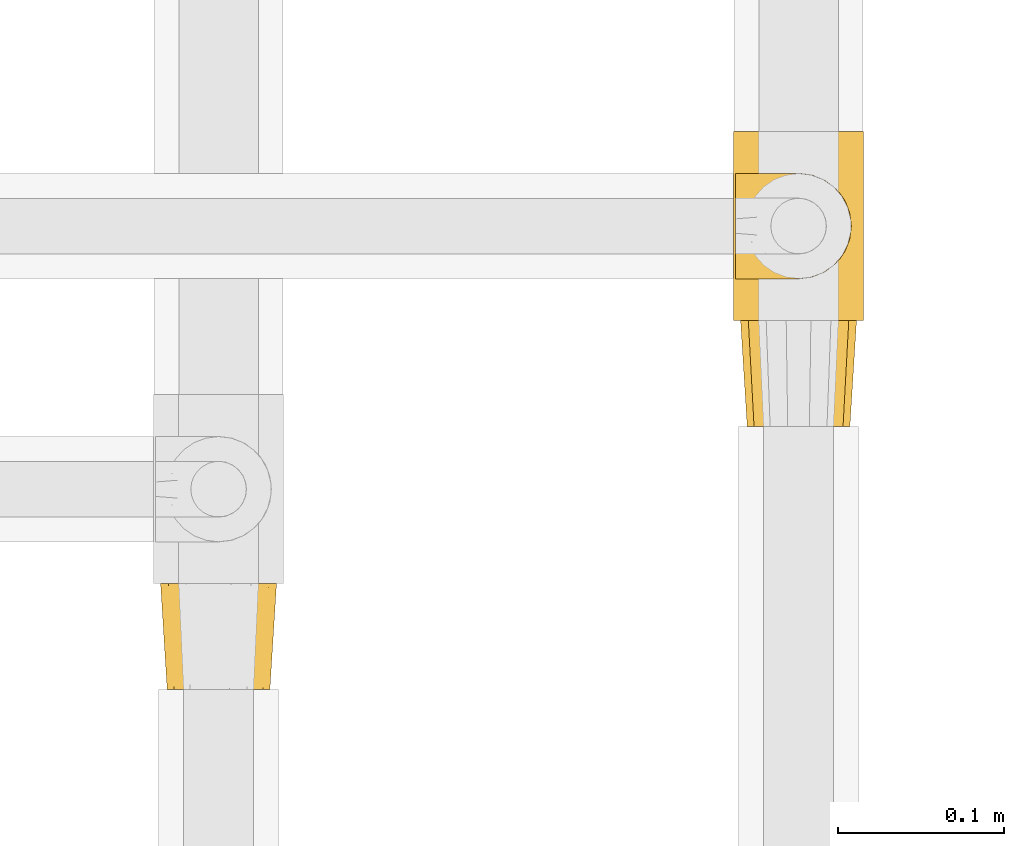
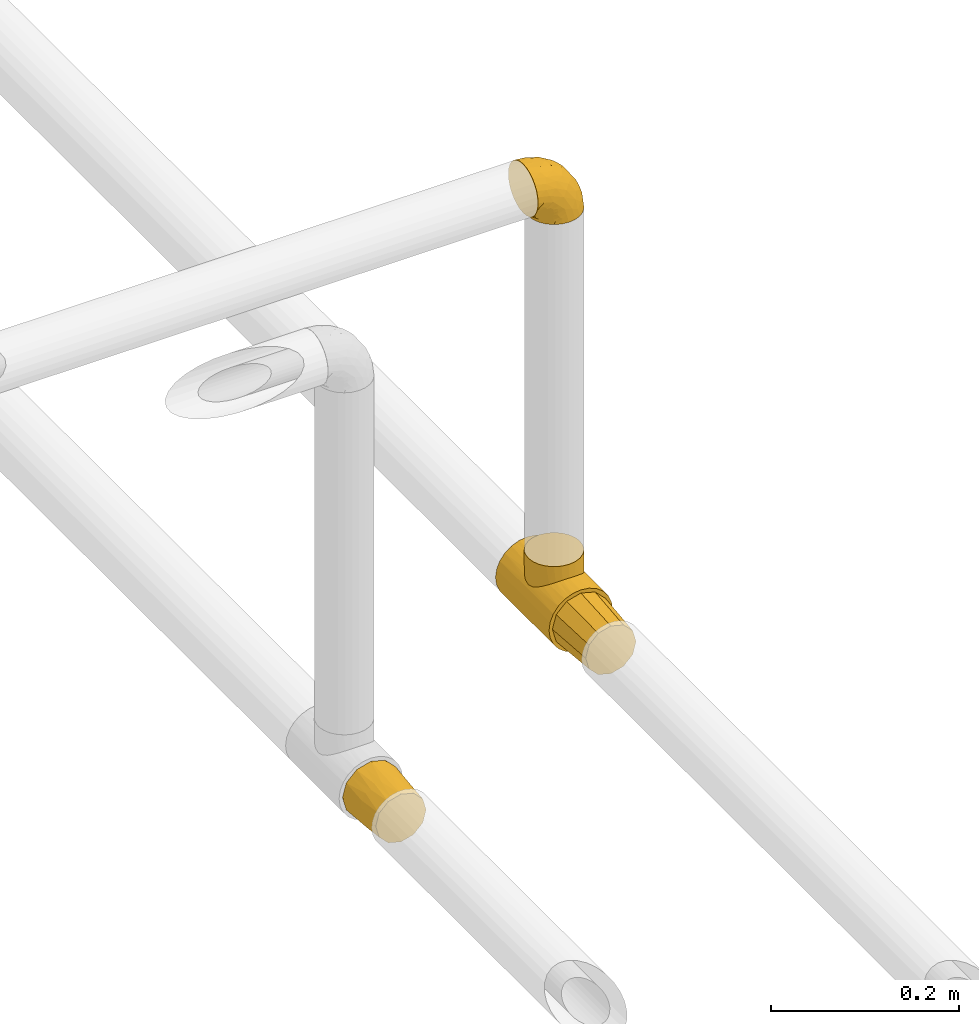
# One storey, part 14 of 38: 4 coverings.
"""IFC2X3 building model written with IfcOpenShell, lengths in millimetres."""

from ifc_helpers import new_model, entity, si_unit, converted_unit, derived_unit, direction, frame, origin, place, context, subcontext, project, spatial, faceted_brep, element, save


model = new_model("IFC2X3")

# Units and contexts
model_context = context("Model", 3, precision=0.01, world=origin(), true_north=direction((6.12303176911189e-17, 1.0)))
body_context = subcontext(model_context, "Body", "Model", "MODEL_VIEW")
ifc_project = project(units=[si_unit("LENGTHUNIT", "METRE", prefix="MILLI"), si_unit("AREAUNIT", "SQUARE_METRE"), si_unit("VOLUMEUNIT", "CUBIC_METRE"), converted_unit("PLANEANGLEUNIT", "DEGREE", entity("IfcRatioMeasure", 0.0174532925199433), si_unit("PLANEANGLEUNIT", "RADIAN"), dimensions=[0, 0, 0, 0, 0, 0, 0]), si_unit("MASSUNIT", "GRAM", prefix="KILO"), derived_unit("MASSDENSITYUNIT", [(si_unit("MASSUNIT", "GRAM", prefix="KILO"), 1), (si_unit("LENGTHUNIT", "METRE"), -3)]), derived_unit("MOMENTOFINERTIAUNIT", [(si_unit("LENGTHUNIT", "METRE"), 4)]), si_unit("TIMEUNIT", "SECOND"), si_unit("FREQUENCYUNIT", "HERTZ"), si_unit("THERMODYNAMICTEMPERATUREUNIT", "DEGREE_CELSIUS"), derived_unit("THERMALTRANSMITTANCEUNIT", [(si_unit("MASSUNIT", "GRAM", prefix="KILO"), 1), (si_unit("THERMODYNAMICTEMPERATUREUNIT", "KELVIN"), -1), (si_unit("TIMEUNIT", "SECOND"), -3)]), derived_unit("VOLUMETRICFLOWRATEUNIT", [(si_unit("LENGTHUNIT", "METRE"), 3), (si_unit("TIMEUNIT", "SECOND"), -1)]), derived_unit("MASSFLOWRATEUNIT", [(si_unit("MASSUNIT", "GRAM", prefix="KILO"), 1), (si_unit("TIMEUNIT", "SECOND"), -1)]), derived_unit("ROTATIONALFREQUENCYUNIT", [(si_unit("TIMEUNIT", "SECOND"), -1)]), si_unit("ELECTRICCURRENTUNIT", "AMPERE"), si_unit("ELECTRICVOLTAGEUNIT", "VOLT"), si_unit("POWERUNIT", "WATT"), si_unit("FORCEUNIT", "NEWTON", prefix="KILO"), si_unit("ILLUMINANCEUNIT", "LUX"), si_unit("LUMINOUSFLUXUNIT", "LUMEN"), si_unit("LUMINOUSINTENSITYUNIT", "CANDELA"), derived_unit("USERDEFINED", [(si_unit("MASSUNIT", "GRAM", prefix="KILO"), -1), (si_unit("LENGTHUNIT", "METRE"), -2), (si_unit("TIMEUNIT", "SECOND"), 3), (si_unit("LUMINOUSFLUXUNIT", "LUMEN"), 1)]), derived_unit("LINEARVELOCITYUNIT", [(si_unit("LENGTHUNIT", "METRE"), 1), (si_unit("TIMEUNIT", "SECOND"), -1)]), si_unit("PRESSUREUNIT", "PASCAL"), derived_unit("USERDEFINED", [(si_unit("LENGTHUNIT", "METRE"), -2), (si_unit("MASSUNIT", "GRAM", prefix="KILO"), 1), (si_unit("TIMEUNIT", "SECOND"), -2)]), derived_unit("LINEARFORCEUNIT", [(si_unit("MASSUNIT", "GRAM", prefix="KILO"), 1), (si_unit("LENGTHUNIT", "METRE"), 1), (si_unit("TIMEUNIT", "SECOND"), -2), (si_unit("LENGTHUNIT", "METRE"), -1)]), derived_unit("PLANARFORCEUNIT", [(si_unit("MASSUNIT", "GRAM", prefix="KILO"), 1), (si_unit("LENGTHUNIT", "METRE"), 1), (si_unit("TIMEUNIT", "SECOND"), -2), (si_unit("LENGTHUNIT", "METRE"), -2)])], contexts=[model_context])

# Site, building, storey
site_placement = place(None, origin())
site = spatial("IfcSite", under=ifc_project, at=site_placement, CompositionType="ELEMENT")
building_placement = place(site_placement, origin())
building = spatial("IfcBuilding", under=site, at=building_placement, CompositionType="ELEMENT")
storey_placement = place(building_placement, frame((0.0, 0.0, 24000.0)))
storey = spatial("IfcBuildingStorey", under=building, at=storey_placement, CompositionType="ELEMENT", Elevation=24000.0)

# Coverings
covering_1_placement = place(storey_placement, frame((31043.4, 8130.17, 2623.4)))
element("IfcCovering", 1, at=covering_1_placement, inside=storey, PredefinedType="INSULATION", context=body_context, shape_type="Brep", body=[
    faceted_brep([(8.36, 0.0, 46.92), (5.59, 0.0, 36.6), (8.36, 0.0, 26.27), (9.75, 0.0, 21.1), (15.42, 0.0, 15.42), (21.09, 0.0, 9.75), (26.27, 0.0, 8.36), (36.59, 0.0, 5.6), (46.92, 0.0, 8.36), (52.09, 0.0, 9.75), (57.77, 0.0, 15.42), (63.44, 0.0, 21.1), (64.83, 0.0, 26.27), (67.59, 0.0, 36.6), (64.83, 0.0, 46.92), (63.44, 0.0, 52.1), (57.77, 0.0, 57.77), (52.09, 0.0, 63.44), (46.92, 0.0, 64.83), (36.59, 0.0, 67.6), (26.27, 0.0, 64.83), (21.09, 0.0, 63.44), (15.42, 0.0, 57.77), (9.75, 0.0, 52.1), (45.35, 64.0, 69.25), (54.1, 64.0, 66.91), (60.5, 64.0, 60.5), (66.91, 64.0, 54.1), (69.25, 64.0, 45.35), (71.6, 64.0, 36.6), (69.25, 64.0, 27.85), (66.91, 64.0, 19.1), (60.5, 64.0, 12.69), (54.1, 64.0, 6.28), (45.35, 64.0, 3.94), (36.6, 64.0, 1.6), (27.85, 64.0, 3.94), (19.1, 64.0, 6.28), (12.69, 64.0, 12.69), (6.28, 64.0, 19.1), (3.94, 64.0, 27.85), (1.6, 64.0, 36.6), (3.94, 64.0, 45.35), (6.28, 64.0, 54.1), (12.69, 64.0, 60.5), (19.1, 64.0, 66.91), (27.85, 64.0, 69.25), (36.6, 64.0, 71.6), (6.68, 32.0, 22.65), (10.56, 28.99, 16.62), (4.58, 28.84, 29.44), (15.12, 32.0, 11.54), (22.65, 32.0, 6.68), (29.44, 28.84, 4.58), (36.59, 32.0, 3.6), (3.59, 32.0, 36.6), (50.54, 32.0, 6.68), (56.57, 28.99, 10.56), (43.75, 28.84, 4.58), (61.65, 32.0, 15.12), (66.51, 32.0, 22.65), (68.61, 28.84, 29.44), (69.59, 32.0, 36.6), (66.51, 32.0, 50.54), (62.63, 28.99, 56.57), (68.61, 28.84, 43.75), (58.07, 32.0, 61.65), (50.54, 32.0, 66.51), (43.75, 28.84, 68.61), (36.59, 32.0, 69.6), (22.65, 32.0, 66.51), (16.62, 28.99, 62.63), (29.44, 28.84, 68.61), (11.54, 32.0, 58.07), (6.68, 32.0, 50.54), (4.58, 28.84, 43.75)], [[[0, 1, 2, 3, 4, 5, 6, 7, 8, 9, 10, 11, 12, 13, 14, 15, 16, 17, 18, 19, 20, 21, 22, 23]], [[24, 25, 26, 27, 28, 29, 30, 31, 32, 33, 34, 35, 36, 37, 38, 39, 40, 41, 42, 43, 44, 45, 46, 47]], [[48, 40, 39]], [[39, 49, 48]], [[41, 40, 50]], [[40, 48, 50]], [[38, 49, 39]], [[51, 49, 38]], [[6, 52, 53]], [[5, 4, 51]], [[48, 2, 50]], [[53, 35, 54, 7]], [[4, 49, 51]], [[49, 3, 48]], [[49, 4, 3]], [[48, 3, 2]], [[2, 1, 50]], [[50, 1, 55, 41]], [[38, 37, 51]], [[51, 37, 52]], [[5, 52, 6]], [[52, 5, 51]], [[37, 36, 52]], [[53, 52, 36]], [[7, 6, 53]], [[35, 53, 36]], [[56, 34, 33]], [[33, 57, 56]], [[35, 34, 58]], [[34, 56, 58]], [[32, 57, 33]], [[59, 57, 32]], [[12, 60, 61]], [[11, 10, 59]], [[56, 8, 58]], [[61, 29, 62, 13]], [[10, 57, 59]], [[57, 9, 56]], [[57, 10, 9]], [[56, 9, 8]], [[8, 7, 58]], [[58, 7, 54, 35]], [[32, 31, 59]], [[59, 31, 60]], [[11, 60, 12]], [[60, 11, 59]], [[31, 30, 60]], [[61, 60, 30]], [[13, 12, 61]], [[29, 61, 30]], [[63, 28, 27]], [[27, 64, 63]], [[29, 28, 65]], [[28, 63, 65]], [[26, 64, 27]], [[66, 64, 26]], [[18, 67, 68]], [[17, 16, 66]], [[63, 14, 65]], [[68, 47, 69, 19]], [[16, 64, 66]], [[64, 15, 63]], [[64, 16, 15]], [[63, 15, 14]], [[14, 13, 65]], [[65, 13, 62, 29]], [[26, 25, 66]], [[66, 25, 67]], [[17, 67, 18]], [[67, 17, 66]], [[25, 24, 67]], [[68, 67, 24]], [[19, 18, 68]], [[47, 68, 24]], [[70, 46, 45]], [[45, 71, 70]], [[47, 46, 72]], [[46, 70, 72]], [[44, 71, 45]], [[73, 71, 44]], [[0, 74, 75]], [[23, 22, 73]], [[70, 20, 72]], [[75, 41, 55, 1]], [[22, 71, 73]], [[71, 21, 70]], [[71, 22, 21]], [[70, 21, 20]], [[20, 19, 72]], [[72, 19, 69, 47]], [[44, 43, 73]], [[73, 43, 74]], [[23, 74, 0]], [[74, 23, 73]], [[43, 42, 74]], [[75, 74, 42]], [[1, 0, 75]], [[41, 75, 42]]]),
])
covering_2_placement = place(storey_placement, frame((31389.25, 8352.96, 2619.25)))
element("IfcCovering", 2, at=covering_2_placement, inside=storey, PredefinedType="INSULATION", context=body_context, shape_type="Brep", body=[
    faceted_brep([(60.32, 114.0, 6.84), (50.88, 114.0, 2.93), (40.75, 114.0, 1.6), (30.61, 114.0, 2.93), (21.17, 114.0, 6.84), (13.06, 114.0, 13.06), (6.84, 114.0, 21.17), (2.93, 114.0, 30.61), (1.6, 114.0, 40.75), (2.93, 114.0, 50.88), (6.84, 114.0, 60.32), (13.06, 114.0, 68.43), (17.12, 114.0, 71.54), (21.17, 114.0, 74.65), (25.89, 114.0, 76.61), (30.61, 114.0, 78.56), (35.68, 114.0, 79.23), (40.75, 114.0, 79.9), (45.81, 114.0, 79.23), (50.88, 114.0, 78.56), (55.6, 114.0, 76.61), (60.32, 114.0, 74.65), (64.37, 114.0, 71.54), (68.43, 114.0, 68.43), (74.65, 114.0, 60.32), (78.56, 114.0, 50.88), (79.9, 114.0, 40.75), (78.56, 114.0, 30.61), (74.65, 114.0, 21.17), (68.43, 114.0, 13.06), (2.93, 0.0, 50.88), (1.6, 0.0, 40.75), (2.93, 0.0, 30.61), (6.84, 0.0, 21.17), (13.06, 0.0, 13.06), (21.17, 0.0, 6.84), (30.61, 0.0, 2.93), (40.75, 0.0, 1.6), (50.88, 0.0, 2.93), (60.32, 0.0, 6.84), (68.43, 0.0, 13.06), (74.65, 0.0, 21.17), (78.56, 0.0, 30.61), (79.9, 0.0, 40.75), (78.56, 0.0, 50.88), (74.65, 0.0, 60.32), (68.43, 0.0, 68.43), (64.37, 0.0, 71.54), (60.32, 0.0, 74.65), (55.6, 0.0, 76.61), (50.88, 0.0, 78.56), (45.81, 0.0, 79.23), (40.75, 0.0, 79.9), (35.68, 0.0, 79.23), (30.61, 0.0, 78.56), (25.89, 0.0, 76.61), (21.17, 0.0, 74.65), (17.12, 0.0, 71.54), (13.06, 0.0, 68.43), (6.84, 0.0, 60.32), (15.77, 37.23, 70.9), (12.16, 42.96, 67.49), (20.53, 32.39, 74.27), (29.82, 86.7, 78.17), (26.39, 85.43, 77.17), (9.77, 49.58, 64.69), (8.9, 57.0, 63.51), (9.77, 64.42, 64.69), (37.0, 88.4, 79.53), (40.75, 88.85, 79.9), (40.75, 25.15, 79.9), (37.0, 25.6, 79.53), (12.16, 71.04, 67.49), (15.77, 76.77, 70.9), (20.53, 81.61, 74.27), (26.39, 28.57, 77.17), (33.25, 26.04, 79.17), (29.82, 27.3, 78.17), (33.25, 87.96, 79.17), (44.49, 25.6, 79.53), (48.24, 26.04, 79.17), (55.1, 28.57, 77.17), (60.96, 32.39, 74.27), (51.67, 27.3, 78.17), (48.24, 87.96, 79.17), (44.49, 88.4, 79.53), (55.1, 85.43, 77.17), (60.96, 81.61, 74.27), (51.67, 86.7, 78.17), (65.72, 76.77, 70.9), (65.72, 37.23, 70.9), (69.33, 42.96, 67.49), (71.72, 49.58, 64.69), (72.6, 57.0, 63.51), (69.33, 71.04, 67.49), (71.72, 64.42, 64.69), (8.9, 57.0, 97.75), (9.98, 48.76, 97.75), (13.16, 41.07, 97.75), (18.22, 34.48, 97.75), (24.82, 29.42, 97.75), (32.5, 26.24, 97.75), (40.75, 25.15, 97.75), (48.99, 26.24, 97.75), (56.67, 29.42, 97.75), (63.27, 34.48, 97.75), (68.33, 41.07, 97.75), (71.51, 48.76, 97.75), (72.6, 57.0, 97.75), (71.51, 65.24, 97.75), (68.33, 72.92, 97.75), (63.27, 79.52, 97.75), (56.67, 84.58, 97.75), (48.99, 87.76, 97.75), (40.75, 88.85, 97.75), (32.5, 87.76, 97.75), (24.82, 84.58, 97.75), (18.22, 79.52, 97.75), (13.16, 72.92, 97.75), (9.98, 65.24, 97.75)], [[[0, 1, 2, 3, 4, 5, 6, 7, 8, 9, 10, 11, 12, 13, 14, 15, 16, 17, 18, 19, 20, 21, 22, 23, 24, 25, 26, 27, 28, 29]], [[30, 31, 32, 33, 34, 35, 36, 37, 38, 39, 40, 41, 42, 43, 44, 45, 46, 47, 48, 49, 50, 51, 52, 53, 54, 55, 56, 57, 58, 59]], [[35, 34, 5, 4]], [[3, 2, 37, 36]], [[36, 35, 4, 3]], [[6, 33, 32, 7]], [[7, 32, 31, 8]], [[5, 34, 33, 6]], [[30, 9, 8, 31]], [[59, 10, 9, 30]], [[58, 60, 61]], [[57, 56, 62]], [[63, 14, 64]], [[61, 65, 58]], [[60, 58, 57]], [[58, 65, 59]], [[65, 66, 59]], [[67, 11, 10]], [[17, 68, 69]], [[70, 71, 52]], [[72, 11, 67]], [[73, 11, 72]], [[74, 12, 73]], [[67, 10, 66]], [[66, 10, 59]], [[75, 56, 55]], [[62, 56, 75]], [[76, 54, 53]], [[55, 54, 77]], [[14, 63, 15]], [[52, 71, 53]], [[76, 53, 71]], [[77, 75, 55]], [[74, 13, 12]], [[54, 76, 77]], [[13, 64, 14]], [[64, 13, 74]], [[16, 78, 68]], [[73, 12, 11]], [[17, 16, 68]], [[16, 15, 78]], [[78, 15, 63]], [[60, 57, 62]], [[51, 79, 52]], [[80, 51, 50]], [[49, 48, 81]], [[82, 81, 48]], [[47, 82, 48]], [[50, 83, 80]], [[51, 80, 79]], [[84, 18, 85]], [[85, 17, 69]], [[52, 79, 70]], [[86, 87, 21]], [[17, 85, 18]], [[19, 88, 20]], [[89, 22, 87]], [[20, 88, 86]], [[82, 47, 90]], [[83, 49, 81]], [[90, 46, 91]], [[46, 90, 47]], [[91, 46, 92]], [[49, 83, 50]], [[24, 45, 44, 25]], [[93, 92, 45]], [[45, 92, 46]], [[44, 43, 26, 25]], [[84, 19, 18]], [[94, 95, 23]], [[86, 21, 20]], [[22, 21, 87]], [[23, 89, 94]], [[95, 24, 23]], [[19, 84, 88]], [[93, 24, 95]], [[93, 45, 24]], [[89, 23, 22]], [[27, 42, 41, 28]], [[28, 41, 40, 29]], [[43, 42, 27, 26]], [[0, 39, 38, 1]], [[1, 38, 37, 2]], [[29, 40, 39, 0]], [[96, 97, 98, 99, 100, 101, 102, 103, 104, 105, 106, 107, 108, 109, 110, 111, 112, 113, 114, 115, 116, 117, 118, 119]], [[76, 102, 101]], [[75, 101, 100]], [[102, 76, 71, 70]], [[62, 75, 100]], [[101, 75, 77, 76]], [[100, 99, 62]], [[60, 99, 98]], [[61, 98, 97]], [[65, 97, 96]], [[60, 98, 61]], [[65, 61, 97]], [[66, 65, 96]], [[99, 60, 62]], [[67, 96, 119]], [[72, 119, 118]], [[66, 96, 67]], [[67, 119, 72]], [[118, 73, 72]], [[118, 117, 73]], [[74, 117, 116]], [[64, 116, 115]], [[78, 115, 114]], [[64, 74, 116]], [[114, 69, 68, 78]], [[115, 78, 63, 64]], [[117, 74, 73]], [[84, 114, 113]], [[86, 113, 112]], [[114, 84, 85, 69]], [[87, 86, 112]], [[113, 86, 88, 84]], [[112, 111, 87]], [[89, 111, 110]], [[94, 110, 109]], [[95, 109, 108]], [[89, 110, 94]], [[95, 94, 109]], [[93, 95, 108]], [[111, 89, 87]], [[92, 108, 107]], [[91, 107, 106]], [[93, 108, 92]], [[92, 107, 91]], [[106, 90, 91]], [[106, 105, 90]], [[82, 105, 104]], [[81, 104, 103]], [[80, 103, 102]], [[81, 82, 104]], [[102, 70, 79, 80]], [[103, 80, 83, 81]], [[105, 82, 90]]]),
])
covering_3_placement = place(storey_placement, frame((31390.4, 8376.51, 3160.4)))
element("IfcCovering", 3, at=covering_3_placement, inside=storey, PredefinedType="INSULATION", context=body_context, shape_type="Brep", body=[
    faceted_brep([(1.6, 26.36, 70.65), (1.6, 33.45, 71.45), (1.6, 40.54, 70.65), (1.6, 47.27, 68.29), (1.6, 53.31, 64.49), (1.6, 58.35, 59.45), (1.6, 62.14, 53.41), (1.6, 64.5, 46.68), (1.6, 65.3, 39.6), (1.6, 64.86, 35.69), (1.6, 64.5, 32.5), (1.6, 63.32, 29.14), (1.6, 62.14, 25.77), (1.6, 58.34, 19.73), (1.6, 53.3, 14.69), (1.6, 47.26, 10.9), (1.6, 40.53, 8.54), (1.6, 33.45, 7.75), (1.6, 26.35, 8.54), (1.6, 19.62, 10.9), (1.6, 13.58, 14.7), (1.6, 8.54, 19.74), (1.6, 4.75, 25.78), (1.6, 3.57, 29.15), (1.6, 2.39, 32.51), (1.6, 2.03, 35.69), (1.6, 1.81, 37.64), (1.6, 1.6, 39.6), (1.6, 2.39, 46.69), (1.6, 4.75, 53.42), (1.6, 8.55, 59.46), (1.6, 13.59, 64.5), (1.6, 19.63, 68.29), (23.67, 61.03, 1.6), (27.51, 62.62, 1.6), (31.35, 64.21, 1.6), (35.67, 64.78, 1.6), (37.63, 65.04, 1.6), (39.6, 65.3, 1.6), (47.84, 64.21, 1.6), (55.52, 61.03, 1.6), (62.12, 55.97, 1.6), (67.18, 49.37, 1.6), (70.36, 41.69, 1.6), (71.45, 33.45, 1.6), (70.36, 25.2, 1.6), (67.18, 17.52, 1.6), (62.12, 10.92, 1.6), (55.52, 5.86, 1.6), (47.84, 2.68, 1.6), (39.6, 1.6, 1.6), (35.67, 2.11, 1.6), (31.35, 2.68, 1.6), (27.51, 4.27, 1.6), (23.67, 5.86, 1.6), (20.37, 8.39, 1.6), (17.07, 10.92, 1.6), (12.01, 17.52, 1.6), (8.83, 25.2, 1.6), (7.75, 33.45, 1.6), (8.83, 41.69, 1.6), (12.01, 49.37, 1.6), (17.07, 55.97, 1.6), (20.37, 58.5, 1.6), (33.94, 2.87, 35.56), (20.6, 1.6, 34.5), (24.07, 1.6, 31.03), (27.55, 1.6, 27.55), (31.03, 1.6, 24.07), (34.5, 1.6, 20.6), (68.79, 33.45, 14.96), (53.62, 10.76, 32.2), (50.17, 5.89, 25.13), (58.62, 9.64, 17.37), (67.51, 22.45, 17.86), (61.03, 16.56, 27.91), (64.5, 15.17, 13.85), (17.98, 12.49, 61.37), (61.71, 25.02, 34.87), (52.25, 18.64, 44.22), (16.72, 2.29, 43.56), (39.09, 6.11, 40.93), (25.86, 5.18, 48.36), (44.07, 2.43, 17.22), (44.36, 11.11, 44.67), (31.35, 26.19, 63.86), (17.72, 24.02, 68.09), (29.45, 19.02, 61.87), (52.37, 4.77, 12.15), (35.28, 1.6, 17.69), (36.06, 1.6, 14.79), (36.84, 1.6, 11.89), (37.61, 1.6, 8.99), (38.11, 1.6, 7.14), (38.61, 1.6, 5.29), (14.07, 7.57, 56.77), (13.65, 17.54, 66.08), (14.96, 33.45, 68.79), (13.32, 4.36, 51.2), (3.44, 1.6, 39.1), (5.29, 1.6, 38.61), (8.99, 1.6, 37.61), (11.89, 1.6, 36.84), (14.79, 1.6, 36.06), (17.69, 1.6, 35.28), (29.19, 9.86, 54.2), (28.91, 14.05, 58.65), (68.17, 28.37, 21.36), (28.33, 33.45, 66.13), (53.45, 25.8, 46.99), (58.56, 33.45, 39.66), (50.99, 33.45, 50.99), (43.14, 22.54, 55.34), (39.23, 15.6, 53.83), (66.13, 33.45, 28.33), (45.6, 28.45, 55.34), (39.66, 33.45, 58.56), (18.04, 9.47, 6.06), (22.76, 5.83, 8.03), (21.95, 5.65, 11.06), (32.18, 2.31, 8.19), (29.08, 2.89, 10.89), (20.77, 2.68, 24.37), (4.75, 22.04, 9.23), (11.03, 5.47, 22.33), (6.78, 5.05, 24.59), (5.68, 7.86, 20.19), (7.71, 25.25, 5.45), (4.42, 28.09, 7.56), (5.94, 33.45, 5.94), (14.52, 12.77, 6.36), (11.63, 2.62, 29.84), (6.6, 3.56, 28.12), (7.33, 11.92, 14.94), (12.48, 11.98, 11.12), (7.99, 17.45, 9.87), (11.14, 17.1, 6.36), (14.07, 7.66, 16.34), (15.37, 4.47, 22.18), (10.81, 7.62, 18.62), (7.89, 2.29, 32.34), (26.18, 3.16, 15.29), (5.8, 16.64, 11.7), (9.94, 12.23, 13.14), (22.23, 4.54, 15.04), (18.39, 7.84, 10.61), (17.71, 2.55, 27.21), (16.87, 7.37, 14.05), (13.24, 3.18, 27.14), (24.95, 4.97, 5.74), (26.59, 2.38, 19.92), (26.16, 1.99, 23.61), (22.11, 3.56, 19.14), (17.43, 4.66, 20.12), (4.75, 44.85, 9.23), (5.8, 50.24, 11.69), (7.99, 49.43, 9.87), (14.07, 59.23, 16.33), (10.06, 54.76, 13.17), (11.54, 59.54, 18.65), (7.71, 41.64, 5.45), (7.89, 64.6, 32.33), (8.99, 65.3, 37.61), (11.89, 65.3, 36.84), (14.79, 65.3, 36.06), (4.42, 38.79, 7.56), (22.42, 62.38, 14.85), (27.95, 64.44, 17.26), (22.22, 61.27, 10.58), (39.1, 65.3, 3.44), (36.84, 65.3, 11.89), (37.61, 65.3, 8.99), (38.61, 65.3, 5.29), (21.49, 59.93, 5.65), (26.52, 62.73, 6.88), (18.09, 60.51, 14.93), (18.39, 59.05, 10.6), (13.88, 56.02, 11.09), (11.14, 49.79, 6.36), (32.18, 64.58, 8.19), (34.5, 65.3, 20.6), (31.03, 65.3, 24.07), (11.65, 64.27, 29.86), (5.67, 59.01, 20.16), (6.81, 61.84, 24.58), (5.29, 65.3, 38.61), (7.14, 65.3, 38.11), (7.34, 54.97, 14.93), (36.06, 65.3, 14.79), (31.38, 64.66, 12.32), (19.83, 63.94, 23.91), (27.55, 65.3, 27.55), (22.94, 63.6, 19.33), (6.6, 63.33, 28.11), (17.93, 57.32, 6.0), (14.52, 54.15, 6.44), (17.45, 64.5, 28.13), (11.03, 61.42, 22.32), (17.69, 65.3, 35.28), (20.6, 65.3, 34.5), (12.33, 63.43, 26.65), (30.27, 64.69, 15.34), (35.28, 65.3, 17.69), (25.9, 62.87, 10.31), (24.07, 65.3, 31.03), (58.62, 57.25, 17.37), (13.32, 62.54, 51.19), (16.72, 64.6, 43.56), (44.07, 64.46, 17.22), (61.71, 41.87, 34.87), (67.51, 44.44, 17.86), (61.03, 50.33, 27.92), (50.18, 61.0, 25.12), (33.92, 64.03, 35.57), (39.08, 60.79, 40.93), (53.62, 56.13, 32.19), (68.17, 38.52, 21.36), (52.37, 62.12, 12.15), (64.5, 51.72, 13.85), (25.86, 61.71, 48.35), (14.07, 59.33, 56.76), (29.18, 57.04, 54.19), (29.46, 47.88, 61.86), (17.73, 42.88, 68.09), (31.37, 40.71, 63.85), (17.99, 54.41, 61.36), (53.45, 41.09, 47.0), (39.25, 51.29, 53.81), (28.92, 52.85, 58.64), (13.65, 49.36, 66.07), (52.23, 48.25, 44.24), (43.13, 44.35, 55.34), (44.36, 55.79, 44.67), (45.6, 38.44, 55.34)], [[[0, 1, 2, 3, 4, 5, 6, 7, 8, 9, 10, 11, 12, 13, 14, 15, 16, 17, 18, 19, 20, 21, 22, 23, 24, 25, 26, 27, 28, 29, 30, 31, 32]], [[33, 34, 35, 36, 37, 38, 39, 40, 41, 42, 43, 44, 45, 46, 47, 48, 49, 50, 51, 52, 53, 54, 55, 56, 57, 58, 59, 60, 61, 62, 63]], [[64, 65, 66, 67, 68, 69]], [[45, 44, 70]], [[71, 72, 73]], [[74, 75, 76]], [[77, 31, 30]], [[75, 78, 79]], [[27, 80, 28]], [[74, 46, 45]], [[64, 81, 82]], [[46, 76, 47]], [[83, 50, 49]], [[48, 47, 73]], [[71, 79, 84]], [[85, 86, 87]], [[49, 48, 88]], [[83, 69, 89, 90, 91, 92, 93, 94, 50]], [[95, 77, 30]], [[75, 74, 78]], [[87, 86, 96]], [[96, 86, 32]], [[96, 32, 31]], [[0, 86, 97]], [[83, 64, 69]], [[98, 80, 82]], [[73, 72, 88]], [[64, 80, 65]], [[1, 0, 97]], [[80, 27, 99, 100, 101, 102, 103, 104, 65]], [[77, 105, 106]], [[64, 82, 80]], [[70, 107, 45]], [[77, 95, 105]], [[82, 95, 98]], [[95, 30, 29]], [[74, 107, 78]], [[86, 0, 32]], [[72, 71, 81]], [[85, 108, 86]], [[76, 73, 47]], [[71, 84, 81]], [[109, 110, 111]], [[87, 112, 85]], [[79, 109, 112]], [[79, 112, 113]], [[88, 83, 49]], [[64, 83, 72]], [[31, 77, 96]], [[87, 96, 77]], [[98, 95, 29]], [[105, 95, 82]], [[81, 105, 82]], [[105, 84, 113]], [[29, 28, 98]], [[114, 107, 70]], [[80, 98, 28]], [[73, 75, 71]], [[79, 71, 75]], [[74, 76, 46]], [[73, 76, 75]], [[78, 107, 114]], [[45, 107, 74]], [[87, 113, 112]], [[115, 85, 112]], [[109, 79, 78]], [[113, 87, 106]], [[116, 115, 111]], [[116, 108, 85]], [[79, 113, 84]], [[109, 78, 110]], [[115, 109, 111]], [[85, 115, 116]], [[109, 115, 112]], [[72, 81, 64]], [[105, 81, 84]], [[73, 88, 48]], [[83, 88, 72]], [[86, 108, 97]], [[78, 114, 110]], [[113, 106, 105]], [[87, 77, 106]], [[117, 118, 119]], [[52, 120, 54, 53]], [[91, 120, 52]], [[91, 90, 120]], [[90, 121, 120]], [[122, 67, 66]], [[18, 123, 19]], [[124, 125, 126]], [[127, 59, 58]], [[128, 129, 127]], [[130, 57, 117]], [[131, 132, 125]], [[19, 133, 20]], [[128, 18, 17]], [[134, 135, 136]], [[137, 138, 139]], [[131, 103, 140]], [[22, 140, 23]], [[131, 65, 104, 103]], [[99, 27, 26, 25, 24, 101, 100]], [[141, 118, 121]], [[19, 123, 142]], [[52, 51, 50, 94, 93, 92, 91]], [[129, 128, 17]], [[117, 56, 118]], [[135, 134, 143]], [[139, 126, 133]], [[119, 144, 145]], [[127, 135, 123]], [[136, 58, 57]], [[101, 24, 23]], [[124, 138, 146]], [[140, 101, 23]], [[145, 147, 134]], [[140, 132, 131]], [[140, 103, 102, 101]], [[140, 22, 132]], [[146, 148, 124]], [[121, 69, 141]], [[55, 149, 118]], [[150, 151, 152]], [[147, 137, 134]], [[144, 150, 152]], [[152, 151, 122]], [[138, 122, 146]], [[59, 127, 129]], [[123, 18, 128]], [[58, 136, 127]], [[135, 127, 136]], [[121, 90, 89, 69]], [[120, 121, 149]], [[122, 66, 146]], [[153, 122, 138]], [[141, 69, 68]], [[127, 123, 128]], [[123, 135, 142]], [[143, 142, 135]], [[19, 142, 133]], [[66, 65, 146]], [[148, 65, 131]], [[22, 21, 132]], [[125, 132, 21]], [[126, 125, 21]], [[148, 125, 124]], [[21, 20, 126]], [[133, 126, 20]], [[139, 138, 124]], [[153, 138, 137]], [[126, 139, 124]], [[139, 133, 143]], [[147, 153, 137]], [[152, 122, 153]], [[134, 136, 130]], [[137, 139, 143]], [[144, 147, 145]], [[153, 147, 152]], [[65, 148, 146]], [[125, 148, 131]], [[141, 144, 119]], [[55, 54, 149]], [[137, 143, 134]], [[142, 143, 133]], [[130, 117, 145]], [[57, 56, 117]], [[134, 130, 145]], [[57, 130, 136]], [[150, 144, 141]], [[147, 144, 152]], [[141, 68, 150]], [[151, 68, 67]], [[117, 119, 145]], [[141, 119, 118]], [[68, 151, 150]], [[122, 151, 67]], [[118, 56, 55]], [[120, 149, 54]], [[118, 149, 121]], [[154, 155, 156]], [[157, 158, 159]], [[129, 160, 59]], [[161, 162, 163, 164]], [[165, 160, 129]], [[166, 167, 168]], [[169, 38, 37, 36, 35, 170, 171, 172]], [[63, 173, 174]], [[175, 176, 177]], [[60, 178, 61]], [[179, 35, 34, 33]], [[160, 60, 59]], [[180, 167, 181]], [[129, 17, 165]], [[182, 161, 164]], [[183, 13, 184]], [[9, 8, 185, 186, 162, 10]], [[187, 155, 15]], [[188, 179, 189]], [[187, 15, 14]], [[190, 191, 192]], [[182, 193, 161]], [[194, 176, 168]], [[176, 195, 177]], [[196, 190, 197]], [[11, 10, 162]], [[11, 161, 12]], [[187, 14, 183]], [[12, 161, 193]], [[156, 158, 177]], [[165, 17, 16]], [[194, 195, 176]], [[187, 159, 158]], [[179, 174, 189]], [[182, 164, 198, 199]], [[200, 199, 196]], [[193, 184, 13]], [[194, 168, 173]], [[201, 202, 189]], [[16, 154, 165]], [[160, 156, 178]], [[160, 165, 154]], [[178, 60, 160]], [[170, 35, 179]], [[188, 170, 179]], [[189, 174, 203]], [[174, 179, 33]], [[201, 189, 203]], [[181, 192, 191]], [[167, 180, 201]], [[192, 175, 190]], [[159, 190, 157]], [[15, 154, 16]], [[204, 196, 199]], [[204, 191, 190]], [[160, 154, 156]], [[15, 155, 154]], [[158, 155, 187]], [[203, 173, 168]], [[192, 181, 167]], [[190, 196, 204]], [[200, 196, 197]], [[184, 193, 182]], [[13, 12, 193]], [[200, 184, 182]], [[184, 200, 183]], [[187, 183, 197]], [[14, 13, 183]], [[162, 161, 11]], [[63, 62, 173]], [[174, 33, 63]], [[173, 62, 194]], [[174, 173, 203]], [[62, 61, 194]], [[195, 61, 178]], [[61, 195, 194]], [[177, 195, 178]], [[156, 177, 178]], [[175, 192, 166]], [[166, 168, 176]], [[167, 203, 168]], [[175, 166, 176]], [[167, 166, 192]], [[177, 157, 175]], [[190, 175, 157]], [[187, 197, 159]], [[190, 159, 197]], [[177, 158, 157]], [[155, 158, 156]], [[167, 201, 203]], [[200, 197, 183]], [[202, 201, 180]], [[202, 188, 189]], [[199, 200, 182]], [[41, 40, 205]], [[206, 207, 7]], [[208, 38, 169, 172, 171, 170, 188, 202, 180]], [[209, 210, 211]], [[212, 213, 214]], [[212, 215, 205]], [[43, 210, 216]], [[217, 40, 39]], [[216, 114, 70]], [[208, 213, 212]], [[205, 40, 217]], [[218, 42, 41]], [[216, 209, 114]], [[42, 218, 210]], [[214, 213, 219]], [[219, 220, 221]], [[199, 207, 213]], [[213, 207, 219]], [[8, 7, 207]], [[222, 223, 224]], [[4, 225, 5]], [[2, 97, 223]], [[110, 226, 111]], [[225, 220, 5]], [[227, 221, 228]], [[223, 229, 3]], [[2, 223, 3]], [[230, 231, 226]], [[224, 223, 108]], [[42, 210, 43]], [[230, 209, 211]], [[222, 225, 229]], [[38, 208, 39]], [[3, 229, 4]], [[213, 180, 181, 191, 204, 199]], [[220, 206, 6]], [[5, 220, 6]], [[207, 199, 198, 164, 163, 162, 186, 185, 8]], [[212, 214, 215]], [[218, 205, 211]], [[211, 215, 230]], [[226, 110, 209]], [[222, 231, 227]], [[222, 224, 231]], [[213, 208, 180]], [[217, 208, 212]], [[222, 229, 223]], [[225, 4, 229]], [[221, 220, 225]], [[206, 220, 219]], [[228, 221, 225]], [[214, 221, 232]], [[207, 206, 219]], [[44, 43, 70]], [[7, 6, 206]], [[230, 215, 232]], [[211, 205, 215]], [[205, 218, 41]], [[210, 218, 211]], [[43, 216, 70]], [[209, 216, 210]], [[233, 116, 111]], [[230, 232, 227]], [[224, 116, 233]], [[230, 226, 209]], [[224, 108, 116]], [[230, 227, 231]], [[221, 227, 232]], [[233, 226, 231]], [[225, 222, 228]], [[226, 233, 111]], [[224, 233, 231]], [[221, 214, 219]], [[214, 232, 215]], [[208, 217, 39]], [[205, 217, 212]], [[97, 2, 1]], [[97, 108, 223]], [[110, 114, 209]], [[227, 228, 222]]]),
])
covering_4_placement = place(storey_placement, frame((31393.4, 8288.96, 2623.4)))
element("IfcCovering", 4, at=covering_4_placement, inside=storey, PredefinedType="INSULATION", context=body_context, shape_type="Brep", body=[
    faceted_brep([(21.1, 0.0, 63.44), (15.42, 0.0, 57.77), (9.75, 0.0, 52.1), (7.67, 0.0, 44.35), (5.6, 0.0, 36.6), (7.67, 0.0, 28.85), (9.75, 0.0, 21.1), (15.42, 0.0, 15.42), (21.1, 0.0, 9.75), (28.85, 0.0, 7.67), (36.6, 0.0, 5.6), (44.35, 0.0, 7.67), (52.1, 0.0, 9.75), (57.77, 0.0, 15.42), (63.44, 0.0, 21.1), (65.52, 0.0, 28.85), (67.6, 0.0, 36.6), (65.52, 0.0, 44.35), (63.44, 0.0, 52.1), (57.77, 0.0, 57.77), (52.1, 0.0, 63.44), (44.35, 0.0, 65.52), (36.6, 0.0, 67.6), (28.85, 0.0, 65.52), (69.15, 64.0, 45.72), (71.6, 64.0, 36.6), (69.15, 64.0, 27.47), (66.91, 64.0, 19.1), (60.5, 64.0, 12.69), (54.1, 64.0, 6.28), (45.72, 64.0, 4.04), (36.6, 64.0, 1.6), (27.47, 64.0, 4.04), (19.1, 64.0, 6.28), (12.69, 64.0, 12.69), (6.28, 64.0, 19.1), (4.04, 64.0, 27.47), (1.6, 64.0, 36.6), (4.04, 64.0, 45.72), (6.28, 64.0, 54.1), (12.69, 64.0, 60.5), (19.1, 64.0, 66.91), (27.47, 64.0, 69.15), (36.6, 64.0, 71.6), (45.72, 64.0, 69.15), (54.1, 64.0, 66.91), (60.5, 64.0, 60.5), (66.91, 64.0, 54.1)], [[[0, 1, 2, 3, 4, 5, 6, 7, 8, 9, 10, 11, 12, 13, 14, 15, 16, 17, 18, 19, 20, 21, 22, 23]], [[24, 25, 26, 27, 28, 29, 30, 31, 32, 33, 34, 35, 36, 37, 38, 39, 40, 41, 42, 43, 44, 45, 46, 47]], [[20, 45, 44, 43, 22, 21]], [[47, 46, 45, 20, 19, 18]], [[17, 16, 25, 24, 47, 18]], [[2, 39, 38, 37, 4, 3]], [[41, 40, 39, 2, 1, 0]], [[23, 22, 43, 42, 41, 0]], [[8, 33, 32, 31, 10, 9]], [[35, 34, 33, 8, 7, 6]], [[5, 4, 37, 36, 35, 6]], [[14, 27, 26, 25, 16, 15]], [[29, 28, 27, 14, 13, 12]], [[11, 10, 31, 30, 29, 12]]]),
])

save(model, "model.ifc")
